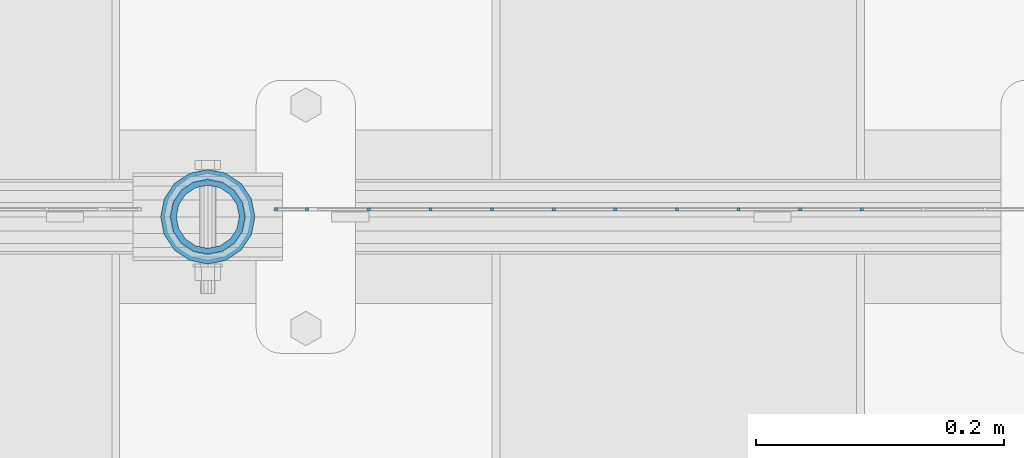
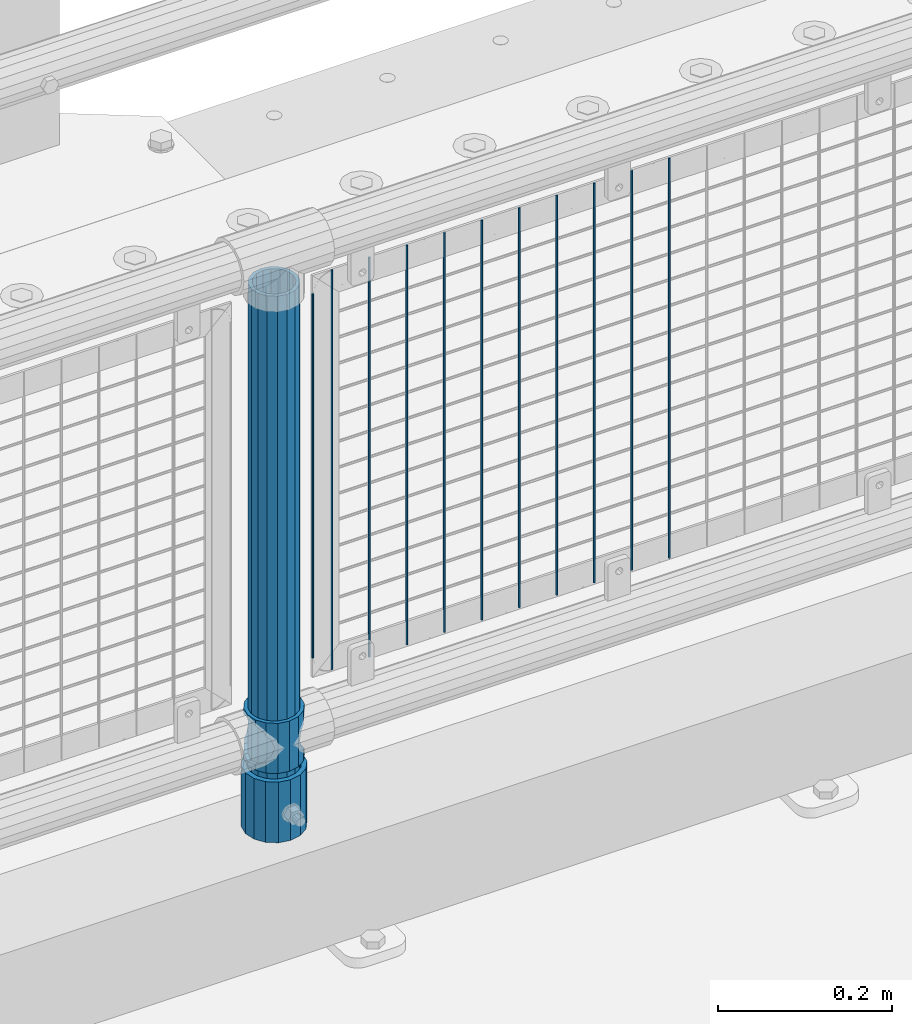
# One storey, part 78 of 247: 14 columns.
"""IFC2X3 building model written with IfcOpenShell, lengths in millimetres."""

from ifc_helpers import new_model, si_unit, frame, origin_with_axes, place, context, subcontext, project, spatial, faceted_brep, material, type_object, element, save


model = new_model("IFC2X3")

# Units and contexts
model_context = context("Model", 3, precision=1e-05, world=origin_with_axes())
body_context = subcontext(model_context, "Body", "Model", "MODEL_VIEW")
ifc_project = project(units=[si_unit("LENGTHUNIT", "METRE", prefix="MILLI"), si_unit("AREAUNIT", "SQUARE_METRE"), si_unit("VOLUMEUNIT", "CUBIC_METRE"), si_unit("MASSUNIT", "GRAM", prefix="KILO"), si_unit("TIMEUNIT", "SECOND"), si_unit("PLANEANGLEUNIT", "RADIAN"), si_unit("SOLIDANGLEUNIT", "STERADIAN"), si_unit("THERMODYNAMICTEMPERATUREUNIT", "DEGREE_CELSIUS"), si_unit("LUMINOUSINTENSITYUNIT", "LUMEN")], contexts=[model_context])

# Site, building, storey
site_placement = place(None, origin_with_axes())
site = spatial("IfcSite", under=ifc_project, at=site_placement, CompositionType="ELEMENT")
building_placement = place(site_placement, origin_with_axes())
building = spatial("IfcBuilding", under=site, at=building_placement, Name="Standard", CompositionType="ELEMENT")
storey_placement = place(building_placement, origin_with_axes())
storey = spatial("IfcBuildingStorey", under=building, at=storey_placement, Name="Undefined", CompositionType="ELEMENT", Elevation=0.0)

# Columns
ifc_material_1 = material()
column_type_1 = type_object("IfcColumnType", PredefinedType="NOTDEFINED")
column_1_placement = place(storey_placement, frame((5421.0, 7664.5, 168.02), z_axis=(0.0, 1.0, 0.0), x_axis=(0.0, 0.0, 1.0)))
element("IfcColumn", 1, at=column_1_placement, inside=storey, type_object=column_type_1, material=ifc_material_1, context=body_context, shape_type="Brep", body=[
    faceted_brep([(0.0, -31.75, 0.0), (0.0, -29.3331751572332, 12.1501989775916), (85.0, -29.3331751572332, 12.1501989775916), (85.0, -31.75, 0.0), (0.0, -22.4506403026735, 22.4506403026726), (85.0, -22.4506403026735, 22.4506403026726), (0.0, -12.1501989775916, 29.3331751572332), (85.0, -12.1501989775916, 29.3331751572332), (0.0, 0.0, 31.75), (85.0, 0.0, 31.75), (0.0, 12.1501989775916, 29.3331751572332), (85.0, 12.1501989775916, 29.3331751572332), (0.0, 22.4506403026735, 22.4506403026726), (85.0, 22.4506403026735, 22.4506403026726), (0.0, 29.3331751572332, 12.1501989775916), (85.0, 29.3331751572332, 12.1501989775916), (0.0, 31.75, 0.0), (85.0, 31.75, 0.0), (0.0, 29.3331751572332, -12.1501989775916), (85.0, 29.3331751572332, -12.1501989775916), (0.0, 22.4506403026735, -22.4506403026726), (85.0, 22.4506403026735, -22.4506403026726), (0.0, 12.1501989775916, -29.3331751572332), (85.0, 12.1501989775916, -29.3331751572332), (0.0, 0.0, -31.75), (85.0, 0.0, -31.75), (0.0, -12.1501989775916, -29.3331751572332), (85.0, -12.1501989775916, -29.3331751572332), (0.0, -22.4506403026735, -22.4506403026726), (85.0, -22.4506403026735, -22.4506403026726), (0.0, -29.3331751572332, -12.1501989775916), (85.0, -29.3331751572332, -12.1501989775916), (0.0, -38.0499999999993, 0.0), (0.0, -35.1536162120537, -14.5611046014919), (85.0, -35.1536162120537, -14.5611046014919), (85.0, -38.0499999999993, 0.0), (0.0, -26.9054130241475, -26.9054130241484), (85.0, -26.9054130241475, -26.9054130241484), (0.0, -14.561104601491, -35.1536162120547), (85.0, -14.561104601491, -35.1536162120547), (0.0, 0.0, -38.0500000000002), (85.0, 0.0, -38.0500000000002), (0.0, 14.561104601491, -35.1536162120547), (85.0, 14.561104601491, -35.1536162120547), (0.0, 26.9054130241475, -26.9054130241484), (85.0, 26.9054130241475, -26.9054130241484), (0.0, 35.1536162120537, -14.5611046014919), (85.0, 35.1536162120537, -14.5611046014919), (0.0, 38.0499999999993, 0.0), (85.0, 38.0499999999993, 0.0), (0.0, 35.1536162120537, 14.5611046014919), (85.0, 35.1536162120537, 14.5611046014919), (0.0, 26.9054130241475, 26.9054130241484), (85.0, 26.9054130241475, 26.9054130241484), (0.0, 14.561104601491, 35.1536162120547), (85.0, 14.561104601491, 35.1536162120547), (0.0, 0.0, 38.0500000000002), (85.0, 0.0, 38.0500000000002), (0.0, -14.561104601491, 35.1536162120547), (85.0, -14.561104601491, 35.1536162120547), (0.0, -26.9054130241475, 26.9054130241484), (85.0, -26.9054130241475, 26.9054130241484), (0.0, -35.1536162120537, 14.5611046014919), (85.0, -35.1536162120537, 14.5611046014919)], [[[0, 1, 2, 3]], [[1, 4, 5, 2]], [[4, 6, 7, 5]], [[6, 8, 9, 7]], [[8, 10, 11, 9]], [[10, 12, 13, 11]], [[12, 14, 15, 13]], [[14, 16, 17, 15]], [[16, 18, 19, 17]], [[18, 20, 21, 19]], [[20, 22, 23, 21]], [[22, 24, 25, 23]], [[24, 26, 27, 25]], [[26, 28, 29, 27]], [[28, 30, 31, 29]], [[30, 0, 3, 31]], [[32, 33, 34, 35]], [[33, 36, 37, 34]], [[36, 38, 39, 37]], [[38, 40, 41, 39]], [[40, 42, 43, 41]], [[42, 44, 45, 43]], [[44, 46, 47, 45]], [[46, 48, 49, 47]], [[48, 50, 51, 49]], [[50, 52, 53, 51]], [[52, 54, 55, 53]], [[54, 56, 57, 55]], [[56, 58, 59, 57]], [[58, 60, 61, 59]], [[60, 62, 63, 61]], [[62, 32, 35, 63]], [[37, 39, 41, 43, 45, 47, 49, 51, 53, 55, 57, 59, 61, 63, 35, 34], [5, 7, 9, 11, 13, 15, 17, 19, 21, 23, 25, 27, 29, 31, 3, 2]], [[62, 60, 58, 56, 54, 52, 50, 48, 46, 44, 42, 40, 38, 36, 33, 32], [30, 28, 26, 24, 22, 20, 18, 16, 14, 12, 10, 8, 6, 4, 1, 0]]]),
])
ifc_material_2 = material(Name="Misc_Undefined")
column_type_2 = type_object("IfcColumnType", PredefinedType="NOTDEFINED")
column_2_placement = place(storey_placement, frame((5421.0, 7664.5, 263.02), z_axis=(-1.0, 0.0, 0.0), x_axis=(0.0, 0.0, 1.0)))
element("IfcColumn", 2, at=column_2_placement, inside=storey, type_object=column_type_2, material=ifc_material_2, context=body_context, shape_type="Brep", body=[
    faceted_brep([(56.6106908090114, 21.4606908090118, -21.4606908090118), (56.6106908090114, 21.4606908090118, -27.1226768591096), (61.9623795176755, 13.4513226476329, -32.4743655677721), (63.1897438117172, 11.6144421722802, -32.839743811719), (63.1897438117172, 11.6144421722802, -28.0397438117179), (46.7644421722801, 28.0397438117179, -11.6144421722802), (46.7644421722801, 28.0397438117179, -20.088203122983), (51.5310424080055, 24.8548033587067, -24.8548033587067), (35.1499999999996, 30.35, 0.0), (35.1499999999996, 30.3500000000004, -16.6306603983649), (23.5355578277192, 28.0397438117179, -11.6144421722802), (23.5355578277192, 28.0397438117179, -20.088203122983), (13.6893091909879, 21.4606908090118, -21.4606908090118), (13.6893091909879, 21.4606908090118, -27.1226768591096), (18.768957591997, 24.8548033587067, -24.8548033587067), (7.11025618828211, 11.6144421722802, -28.0397438117179), (7.11025618828211, 11.6144421722802, -32.839743811719), (8.33762048232387, 13.4513226476329, -32.4743655677721), (4.79999999999961, 0.0, -30.3500000000004), (4.79999999999961, 0.0, -35.1499999999996), (7.11025618828211, -11.6144421722802, -28.0397438117179), (7.11025618828211, -11.6144421722802, -32.839743811719), (13.6893091909879, -21.4606908090118, -21.4606908090118), (13.6893091909879, -21.4606908090118, -27.1226768591077), (8.33762048232325, -13.4513226476329, -32.4743655677721), (23.5355578277191, -28.0397438117179, -11.6144421722802), (23.5355578277191, -28.0397438117179, -20.0882031229885), (18.768957591997, -24.8548033587067, -24.8548033587067), (35.1499999999996, -30.35, 0.0), (35.1499999999996, -30.3500000000004, -16.6306603983739), (46.7644421722801, -28.0397438117179, -11.6144421722802), (46.7644421722801, -28.0397438117179, -20.0882031229885), (56.6106908090114, -21.4606908090118, -21.4606908090118), (56.6106908090114, -21.4606908090118, -27.1226768591077), (51.5310424080038, -24.8548033587067, -24.8548033587067), (63.1897438117172, -11.6144421722802, -28.0397438117179), (63.1897438117172, -11.6144421722802, -32.839743811719), (61.9623795176754, -13.4513226476329, -32.4743655677721), (65.4999999999997, 0.0, -30.3500000000004), (65.4999999999997, 0.0, -35.1499999999996), (0.0, -28.0397438117179, -11.6144421722802), (0.0, -30.3500000000004, 0.0), (0.0, -21.4606908090118, -21.4606908090118), (0.0, -11.6144421722802, -28.0397438117179), (0.0, 0.0, -30.3500000000004), (0.0, 11.6144421722802, -28.0397438117179), (0.0, 21.4606908090118, -21.4606908090118), (0.0, 28.0397438117179, -11.6144421722802), (0.0, 30.3500000000004, 0.0), (0.0, 28.0397438117179, 11.6144421722802), (23.5355578277192, 28.0397438117179, 11.6144421722806), (0.0, 21.4606908090118, 21.4606908090118), (13.6893091909879, 21.4606908090118, 21.4606908090118), (0.0, 11.6144421722802, 28.0397438117179), (7.11025618828211, 11.6144421722802, 28.0397438117175), (0.0, 0.0, 30.3500000000004), (4.79999999999961, 0.0, 30.3499999999999), (0.0, -11.6144421722802, 28.0397438117179), (7.11025618828205, -11.6144421722802, 28.0397438117175), (0.0, -21.4606908090118, 21.4606908090118), (13.6893091909879, -21.4606908090118, 21.4606908090118), (0.0, -28.0397438117179, 11.6144421722802), (23.5355578277191, -28.0397438117179, 11.6144421722806), (0.0, -32.4743655677721, 13.4513226476338), (0.0, -35.1499999999996, 0.0), (70.2999999999993, -35.1499999999996, 0.0), (70.2999999999993, -32.4743655677721, 13.4513226476338), (0.0, 13.4513226476329, -32.4743655677721), (0.0, 24.8548033587067, -24.8548033587067), (0.0, 0.0, -35.1499999999996), (0.0, -13.4513226476329, -32.4743655677721), (0.0, -24.8548033587067, -24.8548033587067), (0.0, -24.8548033587067, 24.8548033587067), (0.0, -13.4513226476329, 32.4743655677721), (0.0, 0.0, 35.1499999999996), (0.0, 13.4513226476329, 32.4743655677721), (0.0, 24.8548033587067, 24.8548033587067), (0.0, 32.4743655677721, 13.4513226476338), (0.0, 35.1499999999996, 0.0), (0.0, 32.4743655677721, -13.4513226476338), (0.0, -32.4743655677721, -13.4513226476338), (70.2999999999993, 32.4743655677721, 13.4513226476338), (70.2999999999993, 35.1499999999996, 0.0), (70.2999999999993, 32.4743655677721, -13.4513226476338), (70.2999999999993, 24.8548033587067, -24.8548033587067), (70.2999999999993, 13.4513226476329, -32.4743655677721), (70.2999999999993, 0.0, -35.1499999999996), (70.2999999999993, -13.4513226476329, -32.4743655677721), (70.2999999999993, -24.8548033587067, -24.8548033587067), (70.2999999999993, -32.4743655677721, -13.4513226476338), (70.2999999999993, 28.0397438117179, 11.6144421722802), (70.2999999999993, 21.4606908090118, 21.4606908090118), (56.6106908090114, 21.4606908090118, 21.4606908090118), (46.7644421722801, 28.0397438117179, 11.6144421722806), (70.2999999999993, 11.6144421722802, 28.0397438117179), (63.1897438117172, 11.6144421722802, 28.0397438117175), (70.2999999999993, 0.0, 30.3500000000004), (65.4999999999997, 0.0, 30.3499999999999), (70.2999999999993, -11.6144421722802, 28.0397438117179), (63.1897438117172, -11.6144421722802, 28.0397438117175), (70.2999999999993, -21.4606908090118, 21.4606908090118), (56.6106908090114, -21.4606908090118, 21.4606908090118), (70.2999999999993, -28.0397438117179, 11.6144421722802), (46.7644421722801, -28.0397438117179, 11.6144421722806), (70.2999999999993, -11.6144421722802, -28.0397438117179), (70.2999999999993, 0.0, -30.3500000000004), (70.2999999999993, -21.4606908090118, -21.4606908090118), (70.2999999999993, -28.0397438117179, -11.6144421722802), (70.2999999999993, -30.3500000000004, 0.0), (70.2999999999993, 24.8548033587067, 24.8548033587067), (70.2999999999993, 13.4513226476329, 32.4743655677721), (70.2999999999993, 0.0, 35.1499999999996), (70.2999999999993, -13.4513226476329, 32.4743655677721), (70.2999999999993, -24.8548033587067, 24.8548033587067), (70.2999999999993, 30.3500000000004, 0.0), (70.2999999999993, 28.0397438117179, -11.6144421722802), (70.2999999999993, 21.4606908090118, -21.4606908090118), (70.2999999999993, 11.6144421722802, -28.0397438117179), (61.9623795176755, 13.4513226476329, 32.4743655677717), (51.5310424080043, 24.8548033587067, 24.8548033587072), (56.6106908090114, 21.4606908090118, 27.1226768591082), (65.4999999999997, 0.0, 35.1500000000001), (63.1897438117172, 11.6144421722802, 32.8397438117177), (63.1897438117172, -11.6144421722802, 32.8397438117177), (61.962379517675, -13.4513226476329, 32.4743655677717), (56.6106908090114, -21.4606908090118, 27.1226768591068), (51.5310424080026, -24.8548033587067, 24.8548033587072), (18.7689575919956, -24.8548033587067, 24.8548033587072), (46.7644421722801, -28.0397438117179, 20.088203122983), (35.1499999999996, -30.3500000000004, 16.6306603983649), (23.5355578277191, -28.0397438117179, 20.088203122983), (8.33762048232268, -13.4513226476329, 32.4743655677717), (13.6893091909879, -21.4606908090118, 27.1226768591068), (4.79999999999961, 0.0, 35.1500000000001), (7.11025618828205, -11.6144421722802, 32.8397438117177), (7.11025618828211, 11.6144421722802, 32.8397438117177), (8.33762048232427, 13.4513226476329, 32.4743655677717), (13.6893091909879, 21.4606908090118, 27.1226768591082), (18.7689575919966, 24.8548033587067, 24.8548033587072), (23.5355578277192, 28.0397438117179, 20.0882031229844), (35.1499999999996, 30.3500000000004, 16.6306603983667), (46.7644421722801, 28.0397438117179, 20.0882031229844)], [[[0, 1, 2, 3, 4]], [[5, 6, 7, 1, 0]], [[8, 9, 6, 5]], [[10, 11, 9, 8]], [[12, 13, 14, 11, 10]], [[15, 16, 17, 13, 12]], [[18, 19, 16, 15]], [[20, 21, 19, 18]], [[22, 23, 24, 21, 20]], [[25, 26, 27, 23, 22]], [[28, 29, 26, 25]], [[30, 31, 29, 28]], [[32, 33, 34, 31, 30]], [[35, 36, 37, 33, 32]], [[38, 39, 36, 35]], [[4, 3, 39, 38]], [[40, 41, 28, 25]], [[42, 40, 25, 22]], [[43, 42, 22, 20]], [[44, 43, 20, 18]], [[45, 44, 18, 15]], [[46, 45, 15, 12]], [[47, 46, 12, 10]], [[48, 47, 10, 8]], [[49, 48, 8, 50]], [[51, 49, 50, 52]], [[53, 51, 52, 54]], [[55, 53, 54, 56]], [[57, 55, 56, 58]], [[59, 57, 58, 60]], [[61, 59, 60, 62]], [[41, 61, 62, 28]], [[63, 64, 65, 66]], [[17, 67, 68, 14, 13]], [[19, 69, 67, 17, 16]], [[70, 69, 19, 21, 24]], [[71, 70, 24, 23, 27]], [[63, 72, 73, 74, 75, 76, 77, 78, 79, 68, 67, 69, 70, 71, 80, 64], [40, 42, 43, 44, 45, 46, 47, 48, 49, 51, 53, 55, 57, 59, 61, 41]], [[78, 77, 81, 82]], [[79, 78, 82, 83]], [[14, 68, 79, 83, 84, 7, 6, 9, 11]], [[84, 85, 2, 1, 7]], [[85, 86, 39, 3, 2]], [[37, 87, 88, 34, 33]], [[39, 86, 87, 37, 36]], [[34, 88, 89, 80, 71, 27, 26, 29, 31]], [[64, 80, 89, 65]], [[90, 91, 92, 93]], [[91, 94, 95, 92]], [[94, 96, 97, 95]], [[96, 98, 99, 97]], [[98, 100, 101, 99]], [[100, 102, 103, 101]], [[104, 105, 38, 35]], [[106, 104, 35, 32]], [[107, 106, 32, 30]], [[108, 107, 30, 28]], [[102, 108, 28, 103]], [[88, 87, 86, 85, 84, 83, 82, 81, 109, 110, 111, 112, 113, 66, 65, 89], [100, 98, 96, 94, 91, 90, 114, 115, 116, 117, 105, 104, 106, 107, 108, 102]], [[118, 110, 109, 119, 120]], [[121, 111, 110, 118, 122]], [[112, 111, 121, 123, 124]], [[113, 112, 124, 125, 126]], [[127, 72, 63, 66, 113, 126, 128, 129, 130]], [[131, 73, 72, 127, 132]], [[133, 74, 73, 131, 134]], [[75, 74, 133, 135, 136]], [[76, 75, 136, 137, 138]], [[119, 109, 81, 77, 76, 138, 139, 140, 141]], [[92, 120, 119, 141, 93]], [[95, 122, 118, 120, 92]], [[97, 121, 122, 95]], [[99, 123, 121, 97]], [[101, 125, 124, 123, 99]], [[103, 128, 126, 125, 101]], [[28, 129, 128, 103]], [[62, 130, 129, 28]], [[60, 132, 127, 130, 62]], [[58, 134, 131, 132, 60]], [[56, 133, 134, 58]], [[54, 135, 133, 56]], [[52, 137, 136, 135, 54]], [[50, 139, 138, 137, 52]], [[8, 140, 139, 50]], [[93, 141, 140, 8]], [[114, 90, 93, 8]], [[115, 114, 8, 5]], [[116, 115, 5, 0]], [[117, 116, 0, 4]], [[105, 117, 4, 38]]]),
])
column_type_3 = type_object("IfcColumnType", PredefinedType="NOTDEFINED")
column_3_placement = place(storey_placement, frame((5421.0, 7664.5, 168.02), z_axis=(-1.0, 0.0, 0.0), x_axis=(0.0, 0.0, 1.0)))
element("IfcColumn", 3, at=column_3_placement, inside=storey, type_object=column_type_3, material=ifc_material_1, context=body_context, shape_type="Brep", body=[
    faceted_brep([(0.0, -25.3500000000004, 0.0), (0.0, -23.4203461491616, 9.70102501045585), (760.0, -23.4203461491616, 9.70102501045585), (760.0, -25.3500000000004, 0.0), (0.0, -17.9251569030794, 17.9251569030785), (760.0, -17.9251569030794, 17.9251569030785), (0.0, -9.70102501045494, 23.4203461491616), (760.0, -9.70102501045494, 23.4203461491616), (0.0, 0.0, 25.3500000000004), (760.0, 0.0, 25.3500000000004), (0.0, 9.70102501045494, 23.4203461491616), (760.0, 9.70102501045494, 23.4203461491616), (0.0, 17.9251569030794, 17.9251569030785), (760.0, 17.9251569030794, 17.9251569030785), (0.0, 23.4203461491616, 9.70102501045585), (760.0, 23.4203461491616, 9.70102501045585), (0.0, 25.3500000000004, 0.0), (760.0, 25.3500000000004, 0.0), (0.0, 23.4203461491616, -9.70102501045585), (760.0, 23.4203461491616, -9.70102501045585), (0.0, 17.9251569030794, -17.9251569030785), (760.0, 17.9251569030794, -17.9251569030785), (0.0, 9.70102501045494, -23.4203461491616), (760.0, 9.70102501045494, -23.4203461491616), (0.0, 0.0, -25.3500000000004), (760.0, 0.0, -25.3500000000004), (0.0, -9.70102501045494, -23.4203461491616), (760.0, -9.70102501045494, -23.4203461491616), (0.0, -17.9251569030794, -17.9251569030785), (760.0, -17.9251569030794, -17.9251569030785), (0.0, -23.4203461491616, -9.70102501045585), (760.0, -23.4203461491616, -9.70102501045585), (0.0, -30.1499999999996, 0.0), (0.0, -27.8549679052148, -11.5379054858076), (760.0, -27.8549679052148, -11.5379054858076), (760.0, -30.1499999999996, 0.0), (0.0, -21.3192694527743, -21.3192694527752), (760.0, -21.3192694527743, -21.3192694527752), (0.0, -11.5379054858076, -27.8549679052157), (760.0, -11.5379054858076, -27.8549679052157), (0.0, 0.0, -30.1499999999996), (760.0, 0.0, -30.1499999999996), (0.0, 11.5379054858076, -27.8549679052157), (760.0, 11.5379054858076, -27.8549679052157), (0.0, 21.3192694527743, -21.3192694527752), (760.0, 21.3192694527743, -21.3192694527752), (0.0, 27.8549679052157, -11.5379054858076), (760.0, 27.8549679052157, -11.5379054858076), (0.0, 30.1499999999996, 0.0), (760.0, 30.1499999999996, 0.0), (0.0, 27.8549679052157, 11.5379054858076), (760.0, 27.8549679052157, 11.5379054858076), (0.0, 21.3192694527743, 21.3192694527752), (760.0, 21.3192694527743, 21.3192694527752), (0.0, 11.5379054858076, 27.8549679052157), (760.0, 11.5379054858076, 27.8549679052157), (0.0, 0.0, 30.1499999999996), (760.0, 0.0, 30.1499999999996), (0.0, -11.5379054858076, 27.8549679052157), (760.0, -11.5379054858076, 27.8549679052157), (0.0, -21.3192694527743, 21.3192694527752), (760.0, -21.3192694527743, 21.3192694527752), (0.0, -27.8549679052157, 11.5379054858076), (760.0, -27.8549679052157, 11.5379054858076)], [[[0, 1, 2, 3]], [[1, 4, 5, 2]], [[4, 6, 7, 5]], [[6, 8, 9, 7]], [[8, 10, 11, 9]], [[10, 12, 13, 11]], [[12, 14, 15, 13]], [[14, 16, 17, 15]], [[16, 18, 19, 17]], [[18, 20, 21, 19]], [[20, 22, 23, 21]], [[22, 24, 25, 23]], [[24, 26, 27, 25]], [[26, 28, 29, 27]], [[28, 30, 31, 29]], [[30, 0, 3, 31]], [[32, 33, 34, 35]], [[33, 36, 37, 34]], [[36, 38, 39, 37]], [[38, 40, 41, 39]], [[40, 42, 43, 41]], [[42, 44, 45, 43]], [[44, 46, 47, 45]], [[46, 48, 49, 47]], [[48, 50, 51, 49]], [[50, 52, 53, 51]], [[52, 54, 55, 53]], [[54, 56, 57, 55]], [[56, 58, 59, 57]], [[58, 60, 61, 59]], [[60, 62, 63, 61]], [[62, 32, 35, 63]], [[37, 39, 41, 43, 45, 47, 49, 51, 53, 55, 57, 59, 61, 63, 35, 34], [5, 7, 9, 11, 13, 15, 17, 19, 21, 23, 25, 27, 29, 31, 3, 2]], [[62, 60, 58, 56, 54, 52, 50, 48, 46, 44, 42, 40, 38, 36, 33, 32], [30, 28, 26, 24, 22, 20, 18, 16, 14, 12, 10, 8, 6, 4, 1, 0]]]),
])
column_type_4 = type_object("IfcColumnType", Name="D3", PredefinedType="NOTDEFINED")
for number, where, z_axis, x_axis in (
    (4, (5947.895, 7670.5, 353.020000000001), (-1.0, 0.0, 0.0), (0.0, 0.0, 1.0)),
    (5, (5898.24, 7670.5, 353.020000000001), (-1.0, 0.0, 0.0), (0.0, 0.0, 1.0)),
    (6, (5848.585, 7670.5, 353.020000000001), (-1.0, 0.0, 0.0), (0.0, 0.0, 1.0)),
    (7, (5798.93, 7670.5, 353.020000000001), (-1.0, 0.0, 0.0), (0.0, 0.0, 1.0)),
    (8, (5749.275, 7670.5, 353.020000000001), (-1.0, 0.0, 0.0), (0.0, 0.0, 1.0)),
    (9, (5699.62, 7670.5, 353.020000000001), (-1.0, 0.0, 0.0), (0.0, 0.0, 1.0)),
    (10, (5649.965, 7670.5, 353.020000000001), (-1.0, 0.0, 0.0), (0.0, 0.0, 1.0)),
    (11, (5600.31034482759, 7670.5, 353.020000000001), (-1.0, 0.0, 0.0), (0.0, 0.0, 1.0)),
    (12, (5550.65517241379, 7670.5, 353.020000000001), (-0.999999999962839, 0.0, 8.62099999968473e-06), (8.62099999949798e-06, 0.0, 0.999999999962839)),
):
    element("IfcColumn", number, at=place(storey_placement, frame(where, z_axis=z_axis, x_axis=x_axis)), inside=storey, type_object=column_type_4, material=ifc_material_2, ObjectType="D3", context=body_context, shape_type="Brep", body=[
        faceted_brep([(1.81898940354586e-12, -1.5, -5.6843418860808e-14), (0.0, -0.75, -1.29903810567703), (560.0, -0.75, -1.29903810567703), (560.0, -1.5, 0.0), (0.0, 0.75, -1.29903810567703), (560.0, 0.75, -1.29903810567703), (1.81898940354586e-12, 1.5, -5.6843418860808e-14), (560.0, 1.5, 0.0), (0.0, 0.75, 1.29903810567703), (560.0, 0.75, 1.29903810567703), (0.0, -0.75, 1.29903810567703), (560.0, -0.75, 1.29903810567703)], [[[0, 1, 2, 3]], [[1, 4, 5, 2]], [[4, 6, 7, 5]], [[6, 8, 9, 7]], [[8, 10, 11, 9]], [[10, 0, 3, 11]], [[5, 7, 9, 11, 3, 2]], [[10, 8, 6, 4, 1, 0]]]),
    ])
column_4_placement = place(storey_placement, frame((5476.0, 7670.5, 378.020000000001), z_axis=(-1.0, 0.0, 0.0), x_axis=(0.0, 0.0, 1.0)))
element("IfcColumn", 13, at=column_4_placement, inside=storey, type_object=column_type_4, material=ifc_material_2, ObjectType="D3", context=body_context, shape_type="Brep", body=[
    faceted_brep([(1.81898940354586e-12, -1.5, -5.6843418860808e-14), (0.0, -0.75, -1.29903810567703), (510.0, -0.75, -1.29903810567703), (510.0, -1.5, 0.0), (0.0, 0.75, -1.29903810567703), (510.0, 0.75, -1.29903810567703), (1.81898940354586e-12, 1.5, -5.6843418860808e-14), (510.0, 1.5, 0.0), (0.0, 0.75, 1.29903810567703), (510.0, 0.75, 1.29903810567703), (0.0, -0.75, 1.29903810567703), (510.0, -0.75, 1.29903810567703)], [[[0, 1, 2, 3]], [[1, 4, 5, 2]], [[4, 6, 7, 5]], [[6, 8, 9, 7]], [[8, 10, 11, 9]], [[10, 0, 3, 11]], [[5, 7, 9, 11, 3, 2]], [[10, 8, 6, 4, 1, 0]]]),
])
column_5_placement = place(storey_placement, frame((5501.0, 7670.5, 353.020000000001), z_axis=(-1.0, 0.0, 0.0), x_axis=(0.0, 0.0, 1.0)))
element("IfcColumn", 14, at=column_5_placement, inside=storey, type_object=column_type_4, material=ifc_material_2, ObjectType="D3", context=body_context, shape_type="Brep", body=[
    faceted_brep([(1.81898940354586e-12, -1.5, -5.6843418860808e-14), (0.0, -0.75, -1.29903810567703), (560.0, -0.75, -1.29903810567703), (560.0, -1.5, 0.0), (0.0, 0.75, -1.29903810567703), (560.0, 0.75, -1.29903810567703), (1.81898940354586e-12, 1.5, -5.6843418860808e-14), (560.0, 1.5, 0.0), (0.0, 0.75, 1.29903810567703), (560.0, 0.75, 1.29903810567703), (0.0, -0.75, 1.29903810567703), (560.0, -0.75, 1.29903810567703)], [[[0, 1, 2, 3]], [[1, 4, 5, 2]], [[4, 6, 7, 5]], [[6, 8, 9, 7]], [[8, 10, 11, 9]], [[10, 0, 3, 11]], [[5, 7, 9, 11, 3, 2]], [[10, 8, 6, 4, 1, 0]]]),
])

save(model, "model.ifc")
